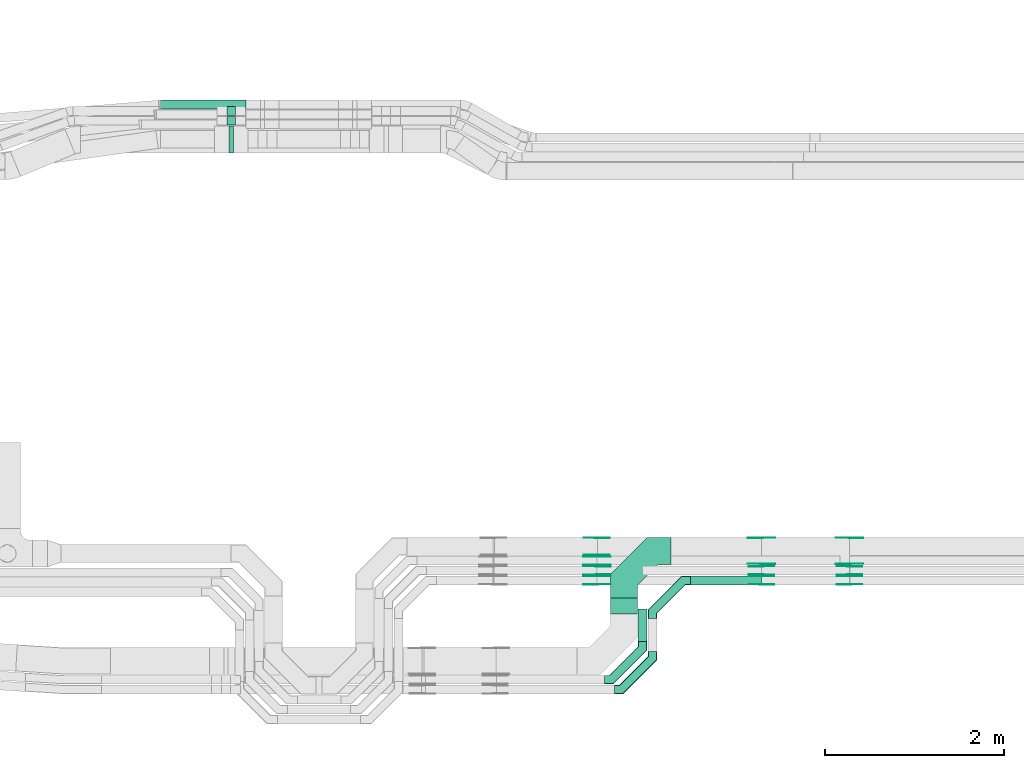
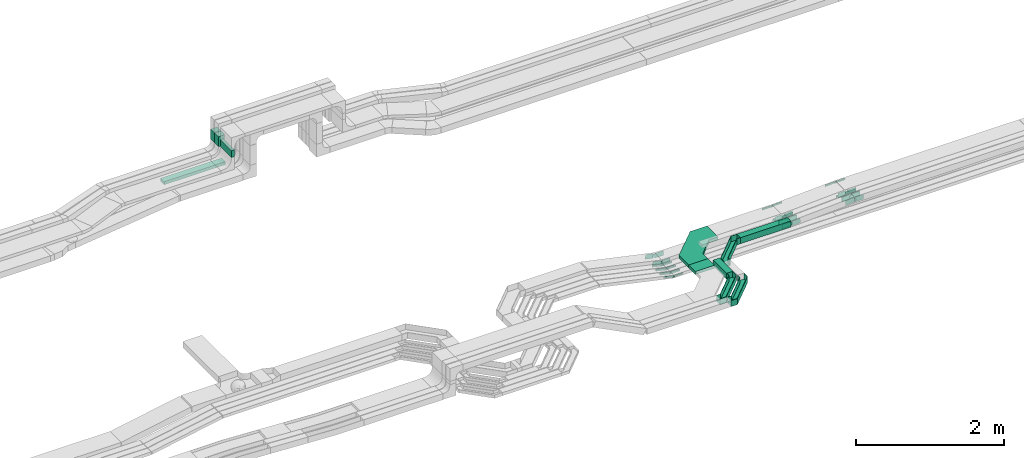
# One storey, part 16 of 33: 44 flow fittings, 7 flow segments.
"""IFC2X3 building model written with IfcOpenShell, lengths in millimetres."""

import ifcopenshell
import ifcopenshell.guid

model = None  # the IFC model being written
_history = None  # IfcOwnerHistory: only IFC2X3 demands one
_inside = {}  # id of a spatial element -> (the spatial element, [elements in it])
_under = {}  # id of a project, library or spatial element -> (it, [spatial elements below it])
_declared = {}  # id of a project -> (the project, [libraries it declares])
_typed = {}  # id of a type object -> (the type object, [elements of that type])
_made_of = {}  # id of a material, layer set ... -> (it, [elements and type objects made of it])


def new_model(schema):
    """Start an empty IFC model of exactly this schema.

    Asked for "IFC4X3", IfcOpenShell would pick the latest addendum, in which some entities
    have other attributes; the version numbers below select the first issue.
    IFC2X3 requires an IfcOwnerHistory on every rooted entity: one is made here for all.
    """
    global model, _history
    if schema == "IFC4X3":
        model = ifcopenshell.file(schema_version=(4, 3, 0, 0))
    else:
        model = ifcopenshell.file(schema=schema)
    _inside.clear()
    _under.clear()
    _declared.clear()
    _typed.clear()
    _made_of.clear()
    _history = None
    if model.schema == "IFC2X3":
        org = make("IfcOrganization", Name="unknown")
        user = make(
            "IfcPersonAndOrganization",
            ThePerson=make("IfcPerson", FamilyName="unknown"),
            TheOrganization=org,
        )
        app = make(
            "IfcApplication",
            ApplicationDeveloper=org,
            Version="unknown",
            ApplicationFullName="unknown",
            ApplicationIdentifier="unknown",
        )
        _history = make(
            "IfcOwnerHistory",
            OwningUser=user,
            OwningApplication=app,
            ChangeAction="ADDED",
            CreationDate=0,
        )
    return model


def make(cls, **values):
    """One entity of the class cls with the attributes given. An attribute that is None is left unset."""
    return model.create_entity(
        cls, **{name: value for name, value in values.items() if value is not None}
    )


def entity(cls, *values):
    """Any entity or typed value of the class cls, its attributes in the order of the schema. None: left unset."""
    e = model.create_entity(cls)
    for i, value in enumerate(values):
        if value is not None:
            e[i] = value
    return e


def rooted(cls, **values):
    """An entity with a GlobalId (a new one), such as an element, a storey or a relation."""
    return make(cls, GlobalId=ifcopenshell.guid.new(), OwnerHistory=_history, **values)


def si_unit(unit_type, name, prefix=None):
    """IfcSIUnit, for example si_unit("LENGTHUNIT", "METRE", prefix="MILLI")."""
    return make("IfcSIUnit", UnitType=unit_type, Prefix=prefix, Name=name)


def converted_unit(unit_type, name, factor, base, dimensions=None, offset=None):
    """IfcConversionBasedUnit, such as the inch: factor (a typed value) times the base unit."""
    return make(
        "IfcConversionBasedUnit"
        if offset is None
        else "IfcConversionBasedUnitWithOffset",
        ConversionOffset=offset,
        Dimensions=None
        if dimensions is None
        else entity("IfcDimensionalExponents", *dimensions),
        UnitType=unit_type,
        Name=name,
        ConversionFactor=make(
            "IfcMeasureWithUnit", ValueComponent=factor, UnitComponent=base
        ),
    )


def derived_unit(unit_type, elements):
    """IfcDerivedUnit: a product of units, each with its exponent."""
    return make(
        "IfcDerivedUnit",
        Elements=[
            make("IfcDerivedUnitElement", Unit=unit, Exponent=power)
            for unit, power in elements
        ],
        UnitType=unit_type,
    )


def assignment(units):
    """IfcUnitAssignment: the units of a project."""
    return None if units is None else make("IfcUnitAssignment", Units=units)


def point(xyz):
    """IfcCartesianPoint."""
    return None if xyz is None else make("IfcCartesianPoint", Coordinates=xyz)


def direction(xyz):
    """IfcDirection."""
    return None if xyz is None else make("IfcDirection", DirectionRatios=xyz)


def frame(location, z_axis=None, x_axis=None):
    """IfcAxis2Placement3D, a coordinate frame: its origin and axes. An axis left out is left unset."""
    return make(
        "IfcAxis2Placement3D",
        Location=point(location),
        Axis=direction(z_axis),
        RefDirection=direction(x_axis),
    )


def frame_2d(location, x_axis=None):
    """IfcAxis2Placement2D, a coordinate frame in the plane: its origin and x axis."""
    return make(
        "IfcAxis2Placement2D", Location=point(location), RefDirection=direction(x_axis)
    )


def origin():
    """The frame at (0, 0, 0) with its axes left unset."""
    return frame((0.0, 0.0, 0.0))


def origin_2d_with_axis():
    """The frame at (0, 0) in the plane with the x axis (1, 0) written out."""
    return frame_2d((0.0, 0.0), x_axis=(1.0, 0.0))


def place(relative_to, where):
    """IfcLocalPlacement: puts the frame where relative to a parent placement (None: the world)."""
    return make(
        "IfcLocalPlacement", PlacementRelTo=relative_to, RelativePlacement=where
    )


def context(
    kind, dimensions, precision=None, world=None, true_north=None, identifier=None
):
    """IfcGeometricRepresentationContext, for example the 3D "Model" context."""
    return make(
        "IfcGeometricRepresentationContext",
        ContextIdentifier=identifier,
        ContextType=kind,
        CoordinateSpaceDimension=dimensions,
        Precision=precision,
        WorldCoordinateSystem=world,
        TrueNorth=true_north,
    )


def subcontext(parent, identifier, kind, view, scale=None):
    """IfcGeometricRepresentationSubContext, for example "Body" below "Model"."""
    return make(
        "IfcGeometricRepresentationSubContext",
        ContextIdentifier=identifier,
        ContextType=kind,
        ParentContext=parent,
        TargetScale=scale,
        TargetView=view,
    )


def project(units=None, contexts=None):
    """IfcProject with its units and contexts."""
    return rooted(
        "IfcProject",
        Name="project",
        RepresentationContexts=contexts,
        UnitsInContext=assignment(units),
    )


def spatial(cls, under=None, at=None, **own):
    """A site, building, storey or space (cls), placed at a placement, below another one or the project."""
    s = rooted(cls, ObjectPlacement=at, **own)
    if under is not None:
        _under.setdefault(under.id(), (under, []))[1].append(s)
    return s


def polyline(points):
    """IfcPolyline through the points."""
    return make("IfcPolyline", Points=[point(p) for p in points])


def circle_curve(where, radius):
    """IfcCircle in the frame where."""
    return make("IfcCircle", Position=where, Radius=radius)


def parameter(value):
    """IfcParameterValue: where a trimmed curve begins or ends, as a parameter of its basis curve."""
    return model.create_entity("IfcParameterValue", value)


def trimmed(basis, trim1, trim2, sense, master):
    """IfcTrimmedCurve: the piece of a basis curve between two trims."""
    return make(
        "IfcTrimmedCurve",
        BasisCurve=basis,
        Trim1=trim1,
        Trim2=trim2,
        SenseAgreement=sense,
        MasterRepresentation=master,
    )


def segment(curve, same_sense, transition):
    """IfcCompositeCurveSegment."""
    return make(
        "IfcCompositeCurveSegment",
        Transition=transition,
        SameSense=same_sense,
        ParentCurve=curve,
    )


def composite_curve(segments, self_intersect=None):
    """IfcCompositeCurve: segments joined end to end."""
    return make("IfcCompositeCurve", Segments=segments, SelfIntersect=self_intersect)


def profile(cls, at=None, kind="AREA", **sizes):
    """A parametric profile (cls). Its sizes go by their IFC names, for example OverallWidth=200.0."""
    return make(cls, ProfileType=kind, Position=at, **sizes)


def rectangle(**sizes):
    """IfcRectangleProfileDef."""
    return profile("IfcRectangleProfileDef", **sizes)


def outline(outer, holes=None, kind="AREA"):
    """IfcArbitraryClosedProfileDef: a profile drawn as a closed curve; with holes, ...WithVoids."""
    if holes is None:
        return make("IfcArbitraryClosedProfileDef", ProfileType=kind, OuterCurve=outer)
    return make(
        "IfcArbitraryProfileDefWithVoids",
        ProfileType=kind,
        OuterCurve=outer,
        InnerCurves=holes,
    )


def extrude(swept, where, along, depth):
    """IfcExtrudedAreaSolid: the profile swept, set in the frame where, extruded along a direction by depth."""
    return make(
        "IfcExtrudedAreaSolid",
        SweptArea=swept,
        Position=where,
        ExtrudedDirection=direction(along),
        Depth=depth,
    )


def faces_of(points, faces, orient=None, outer=None):
    """IfcFace entities. A face is a list of loops; a loop is a list of indices into points, from 0.

    orient and outer hold one flag for each loop. By default every Orientation is true, the
    first loop of a face is its IfcFaceOuterBound and the others are IfcFaceBound.
    """
    made = []
    for i, loops in enumerate(faces):
        bounds = []
        for j, loop in enumerate(loops):
            is_outer = j == 0 if outer is None else outer[i][j]
            bounds.append(
                make(
                    "IfcFaceOuterBound" if is_outer else "IfcFaceBound",
                    Bound=make("IfcPolyLoop", Polygon=[points[k] for k in loop]),
                    Orientation=True if orient is None else orient[i][j],
                )
            )
        made.append(make("IfcFace", Bounds=bounds))
    return made


def faceted_brep(points, faces, orient=None, outer=None, voids=None):
    """IfcFacetedBrep: a solid bounded by flat faces; with voids (closed shells), ...WithVoids."""
    shared = [point(p) for p in points]
    hull = make("IfcClosedShell", CfsFaces=faces_of(shared, faces, orient, outer))
    if voids is None:
        return make("IfcFacetedBrep", Outer=hull)
    return make(
        "IfcFacetedBrepWithVoids",
        Outer=hull,
        Voids=[
            make(cls, CfsFaces=faces_of(shared, fs, o, b)) for cls, fs, o, b in voids
        ],
    )


def shape(context_of_items, identifier, shape_type, items):
    """IfcShapeRepresentation: the items that make up one representation, for example the "Body"."""
    return make(
        "IfcShapeRepresentation",
        ContextOfItems=context_of_items,
        RepresentationIdentifier=identifier,
        RepresentationType=shape_type,
        Items=items,
    )


def source(mapping_origin, context_of_items, identifier, shape_type, items):
    """IfcRepresentationMap: a shape defined once, which mapped items show again and again."""
    return make(
        "IfcRepresentationMap",
        MappingOrigin=mapping_origin,
        MappedRepresentation=shape(context_of_items, identifier, shape_type, items),
    )


def transform(
    local_origin,
    x_axis=None,
    y_axis=None,
    z_axis=None,
    scale=None,
    scale2=None,
    scale3=None,
    uniform=True,
):
    """IfcCartesianTransformationOperator3D, or its non-uniform kind. x_axis, y_axis, z_axis: its Axis1, 2, 3."""
    if uniform:
        return make(
            "IfcCartesianTransformationOperator3D",
            Axis1=direction(x_axis),
            Axis2=direction(y_axis),
            LocalOrigin=point(local_origin),
            Scale=scale,
            Axis3=direction(z_axis),
        )
    return make(
        "IfcCartesianTransformationOperator3DnonUniform",
        Axis1=direction(x_axis),
        Axis2=direction(y_axis),
        LocalOrigin=point(local_origin),
        Scale=scale,
        Axis3=direction(z_axis),
        Scale2=scale2,
        Scale3=scale3,
    )


def mapped(mapping_source, mapping_target):
    """IfcMappedItem: shows the shape of a source again, moved by a transform."""
    return make(
        "IfcMappedItem", MappingSource=mapping_source, MappingTarget=mapping_target
    )


def material(Name=None, Category=None):
    """IfcMaterial."""
    return make("IfcMaterial", Name=Name, Category=Category)


def made_of(thing, what):
    """Note that an element or type object is made of a material, layer set ...; save() writes the relation."""
    if what is not None:
        _made_of.setdefault(what.id(), (what, []))[1].append(thing)
    return thing


def type_object(cls, material=None, **own):
    """A type object (cls), such as IfcWallType, which elements share."""
    return made_of(rooted(cls, **own), material)


def type_shapes(of_type, sources):
    """Give a type object the sources (RepresentationMaps) that its elements show as mapped items."""
    of_type.RepresentationMaps = sources


def element(
    cls,
    number,
    at=None,
    inside=None,
    cuts=None,
    type_object=None,
    material=None,
    context=None,
    identifier="Body",
    shape_type=None,
    held_by="IfcProductDefinitionShape",
    body=None,
    shapes=None,
    **own,
):
    """One element of the class cls, such as IfcWall. Its Tag is "e" and its number.

    at: its placement. inside: the storey or other place that contains it. cuts: it is an
    opening in that element (IfcRelVoidsElement). A single representation is given by context,
    identifier, shape_type and body (its items); several are given by shapes. held_by: the class
    of the entity that holds the representations. save() writes the other relations.
    """
    e = rooted(cls, Tag="e%d" % number, ObjectPlacement=at, **own)
    if body is not None:
        shapes = [shape(context, identifier, shape_type, body)]
    if shapes is not None:
        e.Representation = make(held_by, Representations=shapes)
    if inside is not None:
        _inside.setdefault(inside.id(), (inside, []))[1].append(e)
    if cuts is not None:
        rooted(
            "IfcRelVoidsElement", RelatingBuildingElement=cuts, RelatedOpeningElement=e
        )
    if type_object is not None:
        _typed.setdefault(type_object.id(), (type_object, []))[1].append(e)
    return made_of(e, material)


def aggregate(whole, parts):
    """IfcRelAggregates: a whole, such as a stair, and the parts it consists of."""
    return rooted("IfcRelAggregates", RelatingObject=whole, RelatedObjects=parts)


def save(model, path):
    """Write the relations noted so far, then the file.

    IfcRelAggregates (storeys below a building ...), IfcRelContainedInSpatialStructure (elements
    in a storey), IfcRelDefinesByType, IfcRelAssociatesMaterial and IfcRelDeclares: one each for
    every whole, place, type object, material and project.
    """
    for whole, parts in _under.values():
        aggregate(whole, parts)
    for where, things in _inside.values():
        rooted(
            "IfcRelContainedInSpatialStructure",
            RelatedElements=things,
            RelatingStructure=where,
        )
    for kind, things in _typed.values():
        rooted("IfcRelDefinesByType", RelatedObjects=things, RelatingType=kind)
    for what, things in _made_of.values():
        rooted("IfcRelAssociatesMaterial", RelatedObjects=things, RelatingMaterial=what)
    for by, libraries in _declared.values():
        rooted("IfcRelDeclares", RelatingContext=by, RelatedDefinitions=libraries)
    model.write(path)


model = new_model("IFC2X3")

# Units and contexts
model_context = context("Model", 3, precision=0.01, world=origin(), true_north=direction((6.12303176911189e-17, 1.0)))
body_context = subcontext(model_context, "Body", "Model", "MODEL_VIEW")
ifc_project = project(units=[si_unit("LENGTHUNIT", "METRE", prefix="MILLI"), si_unit("AREAUNIT", "SQUARE_METRE"), si_unit("VOLUMEUNIT", "CUBIC_METRE"), converted_unit("PLANEANGLEUNIT", "DEGREE", entity("IfcRatioMeasure", 0.0174532925199433), si_unit("PLANEANGLEUNIT", "RADIAN"), dimensions=[0, 0, 0, 0, 0, 0, 0]), si_unit("MASSUNIT", "GRAM", prefix="KILO"), derived_unit("MASSDENSITYUNIT", [(si_unit("MASSUNIT", "GRAM", prefix="KILO"), 1), (si_unit("LENGTHUNIT", "METRE"), -3)]), derived_unit("MOMENTOFINERTIAUNIT", [(si_unit("LENGTHUNIT", "METRE"), 4)]), si_unit("TIMEUNIT", "SECOND"), si_unit("FREQUENCYUNIT", "HERTZ"), si_unit("THERMODYNAMICTEMPERATUREUNIT", "DEGREE_CELSIUS"), derived_unit("THERMALTRANSMITTANCEUNIT", [(si_unit("MASSUNIT", "GRAM", prefix="KILO"), 1), (si_unit("THERMODYNAMICTEMPERATUREUNIT", "KELVIN"), -1), (si_unit("TIMEUNIT", "SECOND"), -3)]), derived_unit("VOLUMETRICFLOWRATEUNIT", [(si_unit("LENGTHUNIT", "METRE"), 3), (si_unit("TIMEUNIT", "SECOND"), -1)]), derived_unit("MASSFLOWRATEUNIT", [(si_unit("MASSUNIT", "GRAM", prefix="KILO"), 1), (si_unit("TIMEUNIT", "SECOND"), -1)]), derived_unit("ROTATIONALFREQUENCYUNIT", [(si_unit("TIMEUNIT", "SECOND"), -1)]), si_unit("ELECTRICCURRENTUNIT", "AMPERE"), si_unit("ELECTRICVOLTAGEUNIT", "VOLT"), si_unit("POWERUNIT", "WATT"), si_unit("FORCEUNIT", "NEWTON", prefix="KILO"), si_unit("ILLUMINANCEUNIT", "LUX"), si_unit("LUMINOUSFLUXUNIT", "LUMEN"), si_unit("LUMINOUSINTENSITYUNIT", "CANDELA"), derived_unit("USERDEFINED", [(si_unit("MASSUNIT", "GRAM", prefix="KILO"), -1), (si_unit("LENGTHUNIT", "METRE"), -2), (si_unit("TIMEUNIT", "SECOND"), 3), (si_unit("LUMINOUSFLUXUNIT", "LUMEN"), 1)]), derived_unit("LINEARVELOCITYUNIT", [(si_unit("LENGTHUNIT", "METRE"), 1), (si_unit("TIMEUNIT", "SECOND"), -1)]), si_unit("PRESSUREUNIT", "PASCAL"), derived_unit("USERDEFINED", [(si_unit("LENGTHUNIT", "METRE"), -2), (si_unit("MASSUNIT", "GRAM", prefix="KILO"), 1), (si_unit("TIMEUNIT", "SECOND"), -2)]), derived_unit("LINEARFORCEUNIT", [(si_unit("MASSUNIT", "GRAM", prefix="KILO"), 1), (si_unit("LENGTHUNIT", "METRE"), 1), (si_unit("TIMEUNIT", "SECOND"), -2), (si_unit("LENGTHUNIT", "METRE"), -1)]), derived_unit("PLANARFORCEUNIT", [(si_unit("MASSUNIT", "GRAM", prefix="KILO"), 1), (si_unit("LENGTHUNIT", "METRE"), 1), (si_unit("TIMEUNIT", "SECOND"), -2), (si_unit("LENGTHUNIT", "METRE"), -2)])], contexts=[model_context])

# Site, building, storey
site_placement = place(None, frame((0.0, -0.00077364408347762, 0.0)))
site = spatial("IfcSite", under=ifc_project, at=site_placement, CompositionType="ELEMENT")
building_placement = place(site_placement, origin())
building = spatial("IfcBuilding", under=site, at=building_placement, CompositionType="ELEMENT")
storey_placement = place(building_placement, frame((0.0, 0.0, 8100.0)))
storey = spatial("IfcBuildingStorey", under=building, at=storey_placement, CompositionType="ELEMENT", Elevation=8100.0)

# Flow segments
cable_carrier_segment_type = type_object("IfcCableCarrierSegmentType", PredefinedType="CABLETRAYSEGMENT")
flow_segment_1_placement = place(storey_placement, frame((28807.2101768273, 14970.0572451365, 2570.0)))
element("IfcFlowSegment", 1, at=flow_segment_1_placement, inside=storey, type_object=cable_carrier_segment_type, context=body_context, shape_type="SweptSolid", body=[
    extrude(rectangle(XDim=955.988922105113, YDim=99.9999999999989, at=origin_2d_with_axis()), frame((477.994461052556, 50.0, 0.0), z_axis=(0.0, 0.0, 1.0), x_axis=(-1.0, 0.0, 0.0)), (0.0, 0.0, 1.0), 50.0000000000016),
])
flow_segment_2_placement = place(storey_placement, frame((29548.1990989324, 14900.0572451365, 3050.0)))
element("IfcFlowSegment", 2, at=flow_segment_2_placement, inside=storey, type_object=cable_carrier_segment_type, context=body_context, shape_type="SweptSolid", body=[
    extrude(rectangle(XDim=99.9999999999989, YDim=100.000000000003, at=frame_2d((2.16715534406831e-12, 0.0), x_axis=(1.0, 0.0))), frame((50.0, 50.0, 0.0), z_axis=(0.0, 0.0, 1.0), x_axis=(0.0, 1.0, 0.0)), (0.0, 0.0, 1.0), 164.998679724396),
])
flow_segment_3_placement = place(storey_placement, frame((29548.1990989324, 14790.0572451365, 3050.0)))
element("IfcFlowSegment", 3, at=flow_segment_3_placement, inside=storey, type_object=cable_carrier_segment_type, context=body_context, shape_type="SweptSolid", body=[
    extrude(rectangle(XDim=99.9999999999989, YDim=100.000000000003, at=origin_2d_with_axis()), frame((50.0, 50.0, 0.0), z_axis=(0.0, 0.0, 1.0), x_axis=(0.0, 1.0, 0.0)), (0.0, 0.0, 1.0), 164.998679724392),
])
flow_segment_4_placement = place(storey_placement, frame((29573.1990989324, 14480.0572451366, 3050.01712441882)))
element("IfcFlowSegment", 4, at=flow_segment_4_placement, inside=storey, type_object=cable_carrier_segment_type, context=body_context, shape_type="SweptSolid", body=[
    extrude(rectangle(XDim=300.000000000001, YDim=49.9999999999973, at=origin_2d_with_axis()), frame((25.0, 150.0, 0.0), z_axis=(0.0, 0.0, 1.0), x_axis=(0.0, 1.0, 0.0)), (0.0, 0.0, 1.0), 114.981555305564),
])
flow_segment_5_placement = place(storey_placement, frame((34739.9176052606, 9644.99855346678, 2749.2813532093)))
element("IfcFlowSegment", 5, at=flow_segment_5_placement, inside=storey, type_object=cable_carrier_segment_type, context=body_context, shape_type="SweptSolid", body=[
    extrude(rectangle(XDim=791.634197765681, YDim=100.000000000001, at=frame_2d((-2.1600499167107e-12, -5.43565192856477e-13), x_axis=(1.0, 0.0))), frame((395.817098882843, 50.0, 0.0)), (0.0, 0.0, 1.0), 99.9999999999989),
])
flow_segment_6_placement = place(storey_placement, frame((33844.3227446955, 9318.04668110937, 2750.01711339307)))
element("IfcFlowSegment", 6, at=flow_segment_6_placement, inside=storey, type_object=cable_carrier_segment_type, context=body_context, shape_type="SweptSolid", body=[
    extrude(rectangle(XDim=180.951872357372, YDim=300.000000000001, at=frame_2d((-1.08002495835535e-12, -2.17426077142591e-12), x_axis=(1.0, 0.0))), frame((150.0, 90.4759361787329, 0.0), z_axis=(0.0, 0.0, 1.0), x_axis=(0.0, 1.0, 0.0)), (0.0, 0.0, 1.0), 49.9999999999995),
])
flow_segment_7_placement = place(storey_placement, frame((34153.9176052606, 9008.45182054438, 2750.01096864735)))
element("IfcFlowSegment", 7, at=flow_segment_7_placement, inside=storey, type_object=cable_carrier_segment_type, context=body_context, shape_type="SweptSolid", body=[
    extrude(rectangle(XDim=366.546732922404, YDim=100.000000000003, at=frame_2d((0.0, 2.16715534406831e-12), x_axis=(1.0, 0.0))), frame((50.0, 183.273366461206, 0.0), z_axis=(0.0, 0.0, 1.0), x_axis=(0.0, 1.0, 0.0)), (0.0, 0.0, 1.0), 99.9999999999968),
])

# Flow fittings
ifc_material_1 = material(Name="G")
cable_carrier_fitting_type_1 = type_object("IfcCableCarrierFittingType", PredefinedType="NOTDEFINED", material=ifc_material_1)
shared_shape_1 = source(origin(), body_context, "Body", "SweptSolid", [
    extrude(outline(composite_curve([segment(trimmed(circle_curve(frame_2d((-44.5901162790698, 0.0), x_axis=(1.0, 0.0)), 12.5), [parameter(90.0000000000007)], [parameter(270.0)], True, "PARAMETER"), True, "CONTINUOUS"), segment(polyline([(-44.5901162790697, -12.5), (-33.0901162790698, -12.5)]), True, "CONTINUOUS"), segment(polyline([(-33.0901162790698, -12.5), (-31.2296511627907, -14.5)]), True, "CONTINUOUS"), segment(polyline([(-31.2296511627907, -14.5), (108.90988372093, -14.5)]), True, "CONTINUOUS"), segment(polyline([(108.90988372093, -14.5), (108.90988372093, 14.5)]), True, "CONTINUOUS"), segment(polyline([(108.90988372093, 14.5), (-31.2296511627907, 14.5)]), True, "CONTINUOUS"), segment(polyline([(-31.2296511627907, 14.5), (-33.0901162790698, 12.5)]), True, "CONTINUOUS"), segment(polyline([(-33.0901162790698, 12.5), (-44.5901162790699, 12.5)]), True, "CONTINUOUS")], self_intersect=False)), frame((44.5901162790698, 0.0, 0.0), z_axis=(0.0, 0.0, -1.0), x_axis=(1.0, 0.0, 0.0)), (0.0, 0.0, -1.0), 2.0),
])
type_shapes(cable_carrier_fitting_type_1, [shared_shape_1])
for number, where, z_axis, x_axis in (
    (8, (33692.715360283, 9740.4585534771, 2571.63308707339), (0.0, 1.0, 0.0), (-0.977059422663225, 0.0, 0.212966862645354)),
    (9, (33692.715360283, 9850.45855347702, 2571.31908538346), (0.0, 1.0, 0.0), (-0.977004473697579, 0.0, 0.21321880398998)),
    (10, (33692.715360283, 9960.458553477, 2569.92549664431), (0.0, 1.0, 0.0), (-0.976759892794402, 0.0, 0.214336445403643)),
    (11, (36521.715360283, 9879.5385534566, 2825.0171133931), (0.0, -1.0, 0.0), (-0.998721383285711, 0.0, -0.0505529283808162)),
    (12, (35533.9176052613, 9879.53855345661, 2775.01711339304), (0.0, -1.0, 0.0), (0.998721383285711, 0.0, 0.0505529283808162)),
):
    element("IfcFlowFitting", number, at=place(storey_placement, frame(where, z_axis=z_axis, x_axis=x_axis)), inside=storey, type_object=cable_carrier_fitting_type_1, material=ifc_material_1, context=body_context, shape_type="MappedRepresentation", body=[
        mapped(shared_shape_1, transform((0.0, 0.0, 0.0), scale=1.0)),
    ])
cable_carrier_fitting_type_2 = type_object("IfcCableCarrierFittingType", PredefinedType="NOTDEFINED", material=ifc_material_1)
shared_shape_2 = source(origin(), body_context, "Body", "SweptSolid", [
    extrude(outline(composite_curve([segment(trimmed(circle_curve(frame_2d((-44.5901162790697, 0.0), x_axis=(1.0, 0.0)), 12.5), [parameter(90.0000000000007)], [parameter(270.0)], True, "PARAMETER"), True, "CONTINUOUS"), segment(polyline([(-44.5901162790697, -12.5), (-33.0901162790697, -12.5)]), True, "CONTINUOUS"), segment(polyline([(-33.0901162790697, -12.5), (-31.2296511627907, -14.5)]), True, "CONTINUOUS"), segment(polyline([(-31.2296511627907, -14.5), (108.90988372093, -14.5)]), True, "CONTINUOUS"), segment(polyline([(108.90988372093, -14.5), (108.90988372093, 14.5)]), True, "CONTINUOUS"), segment(polyline([(108.90988372093, 14.5), (-31.2296511627907, 14.5)]), True, "CONTINUOUS"), segment(polyline([(-31.2296511627907, 14.5), (-33.0901162790698, 12.5)]), True, "CONTINUOUS"), segment(polyline([(-33.0901162790698, 12.5), (-44.5901162790699, 12.5)]), True, "CONTINUOUS")], self_intersect=False)), frame((44.5901162790697, 0.0, 0.0)), (0.0, 0.0, 1.0), 2.0),
])
type_shapes(cable_carrier_fitting_type_2, [shared_shape_2])
for number, where, z_axis, x_axis in (
    (13, (33692.715360283, 9649.53855345679, 2571.63308707339), (0.0, -1.0, 0.0), (-0.977059422663225, 0.0, 0.212966862645354)),
    (14, (33692.715360283, 9759.5385534567, 2571.31908538346), (0.0, -1.0, 0.0), (-0.977004473697579, 0.0, 0.21321880398998)),
    (15, (33692.715360283, 9869.53855345668, 2569.92549664431), (0.0, -1.0, 0.0), (-0.976759892794402, 0.0, 0.214336445403643)),
    (16, (36521.715360283, 10170.4585534769, 2825.01711339309), (0.0, 1.0, 0.0), (-0.998721383285711, 0.0, -0.0505529283808162)),
    (17, (35533.9176052613, 10170.4585534769, 2775.01711339304), (0.0, 1.0, 0.0), (0.998721383285711, 0.0, 0.0505529283808162)),
):
    element("IfcFlowFitting", number, at=place(storey_placement, frame(where, z_axis=z_axis, x_axis=x_axis)), inside=storey, type_object=cable_carrier_fitting_type_2, material=ifc_material_1, context=body_context, shape_type="MappedRepresentation", body=[
        mapped(shared_shape_2, transform((0.0, 0.0, 0.0), scale=1.0)),
    ])
cable_carrier_fitting_type_3 = type_object("IfcCableCarrierFittingType", PredefinedType="NOTDEFINED", material=ifc_material_1)
shared_shape_3 = source(origin(), body_context, "Body", "SweptSolid", [
    extrude(outline(composite_curve([segment(trimmed(circle_curve(frame_2d((-44.5901162790698, 0.0), x_axis=(1.0, 0.0)), 12.5), [parameter(90.0000000000007)], [parameter(270.0)], True, "PARAMETER"), True, "CONTINUOUS"), segment(polyline([(-44.5901162790697, -12.5), (-33.0901162790698, -12.5)]), True, "CONTINUOUS"), segment(polyline([(-33.0901162790698, -12.5), (-31.2296511627907, -14.5)]), True, "CONTINUOUS"), segment(polyline([(-31.2296511627907, -14.5), (108.90988372093, -14.5)]), True, "CONTINUOUS"), segment(polyline([(108.90988372093, -14.5), (108.90988372093, 14.5)]), True, "CONTINUOUS"), segment(polyline([(108.90988372093, 14.5), (-31.2296511627907, 14.5)]), True, "CONTINUOUS"), segment(polyline([(-31.2296511627907, 14.5), (-33.0901162790698, 12.5)]), True, "CONTINUOUS"), segment(polyline([(-33.0901162790698, 12.5), (-44.5901162790699, 12.5)]), True, "CONTINUOUS")], self_intersect=False)), frame((44.5901162790698, 0.0, 0.0), z_axis=(0.0, 0.0, -1.0), x_axis=(1.0, 0.0, 0.0)), (0.0, 0.0, -1.0), 2.0),
])
type_shapes(cable_carrier_fitting_type_3, [shared_shape_3])
for number, where, z_axis, x_axis in (
    (18, (33692.715360283, 9651.53855345679, 2571.6330870734), (0.0, -1.0, 0.0), (1.0, 0.0, 0.0)),
    (19, (33692.715360283, 9761.5385534567, 2571.31908538346), (0.0, -1.0, 0.0), (1.0, 0.0, 0.0)),
    (20, (33692.715360283, 9871.53855345668, 2569.92549664431), (0.0, -1.0, 0.0), (1.0, 0.0, 0.0)),
    (21, (36521.715360283, 10168.4585534769, 2825.01711339309), (0.0, 1.0, 0.0), (1.0, 0.0, 0.0)),
    (22, (35533.9176052614, 10168.4585534769, 2775.01711339305), (0.0, 1.0, 0.0), (-1.0, 0.0, 0.0)),
):
    element("IfcFlowFitting", number, at=place(storey_placement, frame(where, z_axis=z_axis, x_axis=x_axis)), inside=storey, type_object=cable_carrier_fitting_type_3, material=ifc_material_1, context=body_context, shape_type="MappedRepresentation", body=[
        mapped(shared_shape_3, transform((0.0, 0.0, 0.0), scale=1.0)),
    ])
cable_carrier_fitting_type_4 = type_object("IfcCableCarrierFittingType", PredefinedType="NOTDEFINED", material=ifc_material_1)
shared_shape_4 = source(origin(), body_context, "Body", "SweptSolid", [
    extrude(outline(composite_curve([segment(trimmed(circle_curve(frame_2d((-44.5901162790697, 0.0), x_axis=(1.0, 0.0)), 12.5), [parameter(90.0000000000007)], [parameter(270.0)], True, "PARAMETER"), True, "CONTINUOUS"), segment(polyline([(-44.5901162790697, -12.5), (-33.0901162790697, -12.5)]), True, "CONTINUOUS"), segment(polyline([(-33.0901162790697, -12.5), (-31.2296511627907, -14.5)]), True, "CONTINUOUS"), segment(polyline([(-31.2296511627907, -14.5), (108.90988372093, -14.5)]), True, "CONTINUOUS"), segment(polyline([(108.90988372093, -14.5), (108.90988372093, 14.5)]), True, "CONTINUOUS"), segment(polyline([(108.90988372093, 14.5), (-31.2296511627907, 14.5)]), True, "CONTINUOUS"), segment(polyline([(-31.2296511627907, 14.5), (-33.0901162790698, 12.5)]), True, "CONTINUOUS"), segment(polyline([(-33.0901162790698, 12.5), (-44.5901162790699, 12.5)]), True, "CONTINUOUS")], self_intersect=False)), frame((44.5901162790697, 0.0, 0.0)), (0.0, 0.0, 1.0), 2.0),
])
type_shapes(cable_carrier_fitting_type_4, [shared_shape_4])
for number, where, z_axis, x_axis in (
    (23, (33692.715360283, 9738.4585534771, 2571.6330870734), (0.0, 1.0, 0.0), (1.0, 0.0, 0.0)),
    (24, (33692.715360283, 9848.45855347702, 2571.31908538347), (0.0, 1.0, 0.0), (1.0, 0.0, 0.0)),
    (25, (33692.715360283, 9958.458553477, 2569.92549664431), (0.0, 1.0, 0.0), (1.0, 0.0, 0.0)),
    (26, (36521.715360283, 9881.53855345661, 2825.01711339309), (0.0, -1.0, 0.0), (1.0, 0.0, 0.0)),
    (27, (35533.9176052614, 9881.53855345661, 2775.01711339305), (0.0, -1.0, 0.0), (-1.0, 0.0, 0.0)),
):
    element("IfcFlowFitting", number, at=place(storey_placement, frame(where, z_axis=z_axis, x_axis=x_axis)), inside=storey, type_object=cable_carrier_fitting_type_4, material=ifc_material_1, context=body_context, shape_type="MappedRepresentation", body=[
        mapped(shared_shape_4, transform((0.0, 0.0, 0.0), scale=1.0)),
    ])
cable_carrier_fitting_type_5 = type_object("IfcCableCarrierFittingType", PredefinedType="NOTDEFINED", material=ifc_material_1)
shared_shape_5 = source(origin(), body_context, "Body", "SweptSolid", [
    extrude(outline(composite_curve([segment(trimmed(circle_curve(frame_2d((-41.4651162790697, 0.0), x_axis=(1.0, 0.0)), 25.0), [parameter(90.0000000000007)], [parameter(270.0)], True, "PARAMETER"), True, "CONTINUOUS"), segment(polyline([(-41.4651162790697, -25.0), (-29.9651162790697, -25.0)]), True, "CONTINUOUS"), segment(polyline([(-29.9651162790697, -25.0), (-28.1046511627907, -38.5)]), True, "CONTINUOUS"), segment(polyline([(-28.1046511627907, -38.5), (99.5348837209303, -38.5)]), True, "CONTINUOUS"), segment(polyline([(99.5348837209303, -38.5), (99.5348837209303, 38.5)]), True, "CONTINUOUS"), segment(polyline([(99.5348837209303, 38.5), (-28.1046511627907, 38.5)]), True, "CONTINUOUS"), segment(polyline([(-28.1046511627907, 38.5), (-29.9651162790697, 25.0)]), True, "CONTINUOUS"), segment(polyline([(-29.9651162790697, 25.0), (-41.46511627907, 25.0)]), True, "CONTINUOUS")], self_intersect=False)), frame((41.4651162790697, 0.0, 0.0), z_axis=(0.0, 0.0, -1.0), x_axis=(1.0, 0.0, 0.0)), (0.0, 0.0, -1.0), 2.0),
])
type_shapes(cable_carrier_fitting_type_5, [shared_shape_5])
for number, where, z_axis, x_axis in (
    (28, (36521.715360283, 9649.53855345661, 2849.28135320933), (0.0, -1.0, 0.0), (-0.998721383285712, 0.0, -0.0505529283807962)),
    (29, (35533.9176052613, 9649.53855345662, 2799.28135320928), (0.0, -1.0, 0.0), (0.998721383285712, 0.0, 0.0505529283807962)),
    (30, (36521.715360283, 9759.53855345661, 2850.01096864737), (0.0, -1.0, 0.0), (-0.998721383285712, 0.0, -0.0505529283807962)),
    (31, (35533.9176052614, 9759.53855345661, 2800.01096864732), (0.0, -1.0, 0.0), (0.998721383285712, 0.0, 0.0505529283807962)),
    (32, (33692.715360283, 10170.4585534769, 2597.39498136104), (0.0, 1.0, 0.0), (-0.977192506439547, 0.0, 0.212355375157765)),
):
    element("IfcFlowFitting", number, at=place(storey_placement, frame(where, z_axis=z_axis, x_axis=x_axis)), inside=storey, type_object=cable_carrier_fitting_type_5, material=ifc_material_1, context=body_context, shape_type="MappedRepresentation", body=[
        mapped(shared_shape_5, transform((0.0, 0.0, 0.0), scale=1.0)),
    ])
cable_carrier_fitting_type_6 = type_object("IfcCableCarrierFittingType", PredefinedType="NOTDEFINED", material=ifc_material_1)
shared_shape_6 = source(origin(), body_context, "Body", "SweptSolid", [
    extrude(outline(composite_curve([segment(trimmed(circle_curve(frame_2d((-41.4651162790697, 0.0), x_axis=(1.0, 0.0)), 25.0), [parameter(90.0000000000007)], [parameter(270.0)], True, "PARAMETER"), True, "CONTINUOUS"), segment(polyline([(-41.4651162790697, -25.0), (-29.9651162790697, -25.0)]), True, "CONTINUOUS"), segment(polyline([(-29.9651162790697, -25.0), (-28.1046511627907, -38.5)]), True, "CONTINUOUS"), segment(polyline([(-28.1046511627907, -38.5), (99.5348837209303, -38.5)]), True, "CONTINUOUS"), segment(polyline([(99.5348837209303, -38.5), (99.5348837209303, 38.5)]), True, "CONTINUOUS"), segment(polyline([(99.5348837209303, 38.5), (-28.1046511627907, 38.5)]), True, "CONTINUOUS"), segment(polyline([(-28.1046511627907, 38.5), (-29.9651162790697, 25.0)]), True, "CONTINUOUS"), segment(polyline([(-29.9651162790697, 25.0), (-41.46511627907, 25.0)]), True, "CONTINUOUS")], self_intersect=False)), frame((41.4651162790697, 0.0, 0.0)), (0.0, 0.0, 1.0), 2.0),
])
type_shapes(cable_carrier_fitting_type_6, [shared_shape_6])
for number, where, z_axis, x_axis in (
    (33, (36521.715360283, 9740.45855347693, 2849.28135320933), (0.0, 1.0, 0.0), (-0.998721383285712, 0.0, -0.0505529283807962)),
    (34, (35533.9176052613, 9740.45855347694, 2799.28135320928), (0.0, 1.0, 0.0), (0.998721383285712, 0.0, 0.0505529283807962)),
    (35, (36521.715360283, 9850.45855347693, 2850.01096864737), (0.0, 1.0, 0.0), (-0.998721383285712, 0.0, -0.0505529283807962)),
    (36, (35533.9176052614, 9850.45855347693, 2800.01096864732), (0.0, 1.0, 0.0), (0.998721383285712, 0.0, 0.0505529283807962)),
    (37, (33692.715360283, 9979.53855345653, 2597.39498136104), (0.0, -1.0, 0.0), (-0.977192506439547, 0.0, 0.212355375157765)),
):
    element("IfcFlowFitting", number, at=place(storey_placement, frame(where, z_axis=z_axis, x_axis=x_axis)), inside=storey, type_object=cable_carrier_fitting_type_6, material=ifc_material_1, context=body_context, shape_type="MappedRepresentation", body=[
        mapped(shared_shape_6, transform((0.0, 0.0, 0.0), scale=1.0)),
    ])
cable_carrier_fitting_type_7 = type_object("IfcCableCarrierFittingType", PredefinedType="NOTDEFINED", material=ifc_material_1)
shared_shape_7 = source(origin(), body_context, "Body", "SweptSolid", [
    extrude(outline(composite_curve([segment(trimmed(circle_curve(frame_2d((-41.4651162790697, 0.0), x_axis=(1.0, 0.0)), 25.0), [parameter(90.0000000000007)], [parameter(270.0)], True, "PARAMETER"), True, "CONTINUOUS"), segment(polyline([(-41.4651162790697, -25.0), (-29.9651162790697, -25.0)]), True, "CONTINUOUS"), segment(polyline([(-29.9651162790697, -25.0), (-28.1046511627907, -38.5)]), True, "CONTINUOUS"), segment(polyline([(-28.1046511627907, -38.5), (99.5348837209303, -38.5)]), True, "CONTINUOUS"), segment(polyline([(99.5348837209303, -38.5), (99.5348837209303, 38.5)]), True, "CONTINUOUS"), segment(polyline([(99.5348837209303, 38.5), (-28.1046511627907, 38.5)]), True, "CONTINUOUS"), segment(polyline([(-28.1046511627907, 38.5), (-29.9651162790697, 25.0)]), True, "CONTINUOUS"), segment(polyline([(-29.9651162790697, 25.0), (-41.46511627907, 25.0)]), True, "CONTINUOUS")], self_intersect=False)), frame((41.4651162790697, 0.0, 0.0), z_axis=(0.0, 0.0, -1.0), x_axis=(1.0, 0.0, 0.0)), (0.0, 0.0, -1.0), 2.0),
])
type_shapes(cable_carrier_fitting_type_7, [shared_shape_7])
for number, where, z_axis, x_axis in (
    (38, (36521.715360283, 9738.45855347693, 2849.28135320933), (0.0, 1.0, 0.0), (1.0, 0.0, 0.0)),
    (39, (35533.9176052613, 9738.45855347694, 2799.28135320929), (0.0, 1.0, 0.0), (-1.0, 0.0, 0.0)),
    (40, (36521.715360283, 9848.45855347693, 2850.01096864737), (0.0, 1.0, 0.0), (1.0, 0.0, 0.0)),
    (41, (35533.9176052614, 9848.45855347693, 2800.01096864732), (0.0, 1.0, 0.0), (-1.0, 0.0, 0.0)),
    (42, (33692.715360283, 9981.53855345653, 2597.39498136105), (0.0, -1.0, 0.0), (1.0, 0.0, 0.0)),
):
    element("IfcFlowFitting", number, at=place(storey_placement, frame(where, z_axis=z_axis, x_axis=x_axis)), inside=storey, type_object=cable_carrier_fitting_type_7, material=ifc_material_1, context=body_context, shape_type="MappedRepresentation", body=[
        mapped(shared_shape_7, transform((0.0, 0.0, 0.0), scale=1.0)),
    ])
cable_carrier_fitting_type_8 = type_object("IfcCableCarrierFittingType", PredefinedType="NOTDEFINED", material=ifc_material_1)
shared_shape_8 = source(origin(), body_context, "Body", "SweptSolid", [
    extrude(outline(composite_curve([segment(trimmed(circle_curve(frame_2d((-41.4651162790697, 0.0), x_axis=(1.0, 0.0)), 25.0), [parameter(90.0000000000007)], [parameter(270.0)], True, "PARAMETER"), True, "CONTINUOUS"), segment(polyline([(-41.4651162790697, -25.0), (-29.9651162790697, -25.0)]), True, "CONTINUOUS"), segment(polyline([(-29.9651162790697, -25.0), (-28.1046511627907, -38.5)]), True, "CONTINUOUS"), segment(polyline([(-28.1046511627907, -38.5), (99.5348837209303, -38.5)]), True, "CONTINUOUS"), segment(polyline([(99.5348837209303, -38.5), (99.5348837209303, 38.5)]), True, "CONTINUOUS"), segment(polyline([(99.5348837209303, 38.5), (-28.1046511627907, 38.5)]), True, "CONTINUOUS"), segment(polyline([(-28.1046511627907, 38.5), (-29.9651162790697, 25.0)]), True, "CONTINUOUS"), segment(polyline([(-29.9651162790697, 25.0), (-41.46511627907, 25.0)]), True, "CONTINUOUS")], self_intersect=False)), frame((41.4651162790697, 0.0, 0.0)), (0.0, 0.0, 1.0), 2.0),
])
type_shapes(cable_carrier_fitting_type_8, [shared_shape_8])
for number, where, z_axis, x_axis in (
    (43, (36521.715360283, 9651.53855345661, 2849.28135320932), (0.0, -1.0, 0.0), (1.0, 0.0, 0.0)),
    (44, (35533.9176052613, 9651.53855345662, 2799.28135320929), (0.0, -1.0, 0.0), (-1.0, 0.0, 0.0)),
    (45, (36521.715360283, 9761.53855345661, 2850.01096864736), (0.0, -1.0, 0.0), (1.0, 0.0, 0.0)),
    (46, (35533.9176052614, 9761.53855345662, 2800.01096864733), (0.0, -1.0, 0.0), (-1.0, 0.0, 0.0)),
    (47, (33692.715360283, 10168.4585534768, 2597.39498136105), (0.0, 1.0, 0.0), (1.0, 0.0, 0.0)),
):
    element("IfcFlowFitting", number, at=place(storey_placement, frame(where, z_axis=z_axis, x_axis=x_axis)), inside=storey, type_object=cable_carrier_fitting_type_8, material=ifc_material_1, context=body_context, shape_type="MappedRepresentation", body=[
        mapped(shared_shape_8, transform((0.0, 0.0, 0.0), scale=1.0)),
    ])
ifc_material_2 = material()
cable_carrier_fitting_type_9 = type_object("IfcCableCarrierFittingType", Name="470_DKC_G5_Sheet horizontal bend:-", PredefinedType="NOTDEFINED", material=ifc_material_2)
shared_shape_9 = source(origin(), body_context, "Body", "SweptSolid", [
    extrude(outline(polyline([(-313.25, -362.749999999999), (-50.1179656440353, -362.749999999999), (362.749999999999, 50.1179656440352), (362.75, 313.249999999999), (62.7500000000001, 313.25), (62.7499999999997, 174.382034355964), (-174.382034355964, -62.7499999999997), (-313.25, -62.7499999999995), (-313.25, -362.749999999999)])), frame((-212.749999999993, 212.749999999989, -25.0)), (0.0, 0.0, 1.0), 50.0000000000003),
])
type_shapes(cable_carrier_fitting_type_9, [shared_shape_9])
flow_fitting_1_placement = place(storey_placement, frame((33994.3227446955, 10024.9985534668, 2775.01711339307), z_axis=(0.0, 0.0, 1.0), x_axis=(-1.0, 0.0, 0.0)))
element("IfcFlowFitting", 48, at=flow_fitting_1_placement, inside=storey, type_object=cable_carrier_fitting_type_9, material=ifc_material_2, Name="470_DKC_G5_Sheet horizontal bend:-", ObjectType="470_DKC_G5_Sheet horizontal bend:-", context=body_context, shape_type="MappedRepresentation", body=[
    mapped(shared_shape_9, transform((0.0, 0.0, 0.0), scale=1.0)),
])
cable_carrier_fitting_type_10 = type_object("IfcCableCarrierFittingType", Name="470_DKC_G5_Sheet horizontal bend:-", PredefinedType="NOTDEFINED", material=ifc_material_2)
shared_shape_10 = source(origin(), body_context, "Body", "Brep", [
    faceted_brep([(-426.0, -50.0, -50.0), (-426.0, -50.0, 50.0), (-426.0, -45.0, 50.0), (-426.0, -45.0, -45.0), (-426.0, 45.0, -45.0), (-426.0, 45.0, 50.0), (-426.0, 50.0, 50.0), (-426.0, 50.0, -50.0), (50.0, 426.0, -50.0), (-50.0, 426.0, -50.0), (-50.0, 426.0, 50.0), (-45.0, 426.0, 50.0), (-45.0, 426.0, -45.0), (45.0, 426.0, -45.0), (45.0, 426.0, 50.0), (50.0, 426.0, 50.0), (-329.289321881337, -50.0, -50.0), (-329.289321881337, -50.0, 50.0), (50.0, 329.289321881334, 50.0), (45.0, 331.3603896932, 50.0), (-331.360389693203, -45.0, 50.0), (-331.360389693203, -45.0, -45.0), (45.0, 331.3603896932, -45.0), (-45.0, 368.639610306778, -45.0), (-368.639610306781, 45.0, -45.0), (-368.639610306781, 45.0, 50.0), (-45.0, 368.639610306778, 50.0), (-50.0, 370.710678118644, 50.0), (-370.710678118647, 50.0, 50.0), (-370.710678118647, 50.0, -50.0), (-50.0, 370.710678118644, -50.0), (50.0, 329.289321881334, -50.0)], [[[0, 1, 2, 3, 4, 5, 6, 7]], [[8, 9, 10, 11, 12, 13, 14, 15]], [[1, 0, 16, 17]], [[2, 1, 17, 18, 15, 14, 19, 20]], [[3, 2, 20, 21]], [[4, 3, 21, 22, 13, 12, 23, 24]], [[5, 4, 24, 25]], [[6, 5, 25, 26, 11, 10, 27, 28]], [[7, 6, 28, 29]], [[0, 7, 29, 30, 9, 8, 31, 16]], [[17, 16, 31, 18]], [[21, 20, 19, 22]], [[25, 24, 23, 26]], [[29, 28, 27, 30]], [[18, 31, 8, 15]], [[22, 19, 14, 13]], [[26, 23, 12, 11]], [[30, 27, 10, 9]]]),
])
type_shapes(cable_carrier_fitting_type_10, [shared_shape_10])
for number, where, name in (
    (49, (34203.9176052606, 8582.45182054441, 2800.01096864736), "470_DKC_G5_Sheet horizontal bend:-"),
    (50, (34313.9176052606, 8472.4518205444, 2799.28135320932), "470_DKC_G5_Sheet horizontal bend:-"),
):
    element("IfcFlowFitting", number, at=place(storey_placement, frame(where)), inside=storey, type_object=cable_carrier_fitting_type_10, material=ifc_material_2, Name=name, ObjectType="470_DKC_G5_Sheet horizontal bend:-", context=body_context, shape_type="MappedRepresentation", body=[
        mapped(shared_shape_10, transform((0.0, 0.0, 0.0), scale=1.0)),
    ])
flow_fitting_2_placement = place(storey_placement, frame((34313.9176052606, 9694.99855346679, 2799.28135320932), z_axis=(0.0, 0.0, 1.0), x_axis=(-1.0, 0.0, 0.0)))
element("IfcFlowFitting", 51, at=flow_fitting_2_placement, inside=storey, type_object=cable_carrier_fitting_type_10, material=ifc_material_2, Name="470_DKC_G5_Sheet horizontal bend:-", ObjectType="470_DKC_G5_Sheet horizontal bend:-", context=body_context, shape_type="MappedRepresentation", body=[
    mapped(shared_shape_10, transform((0.0, 0.0, 0.0), scale=1.0)),
])

save(model, "model.ifc")
